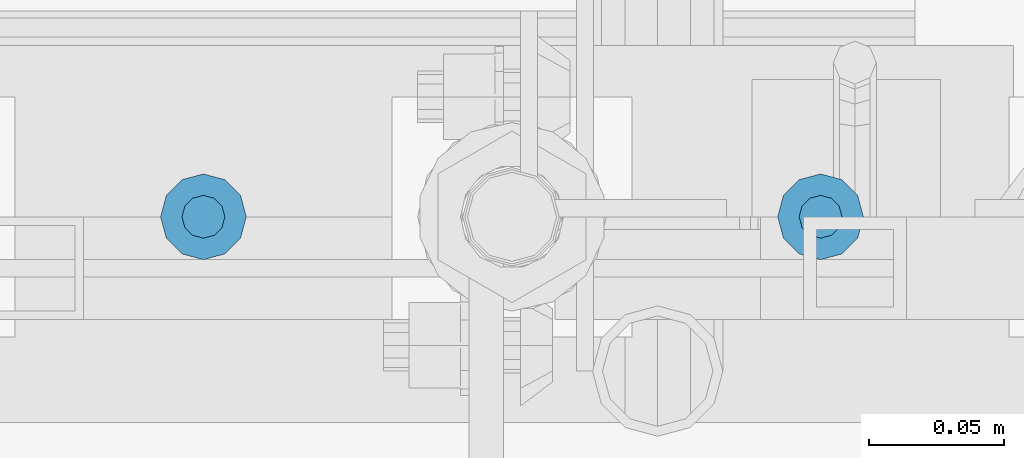
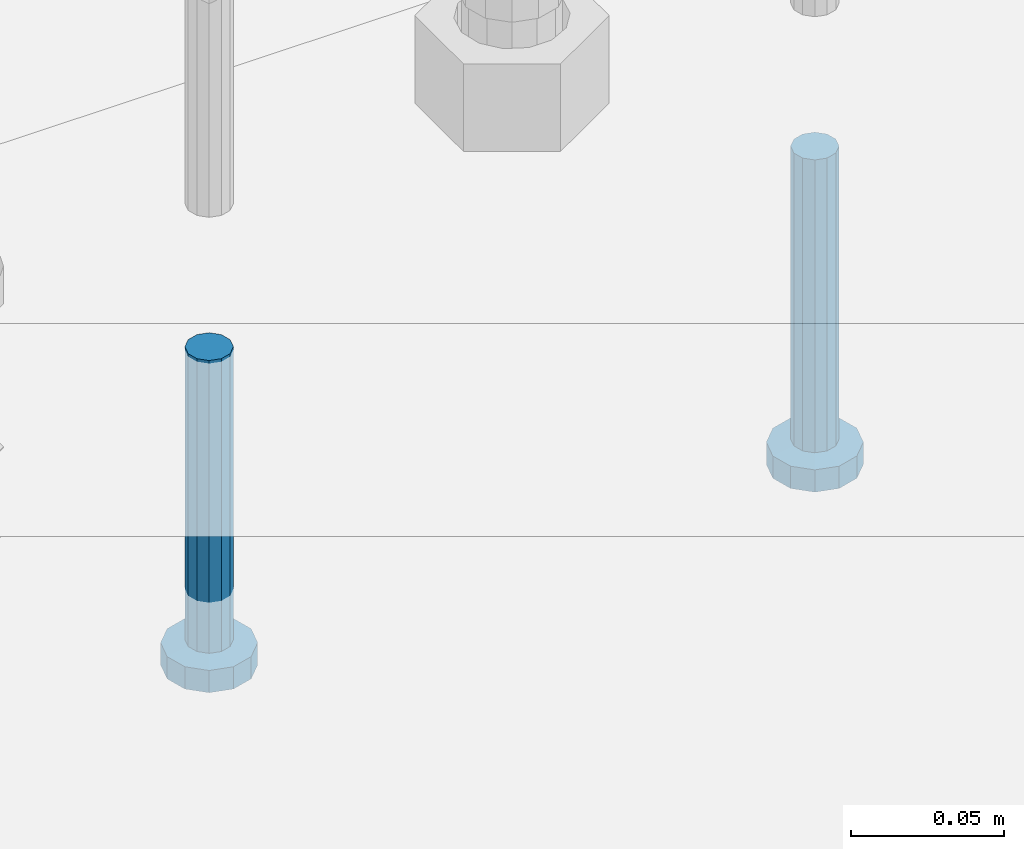
# One storey, part 1139 of 1876: 2 beams, 1 element without a shape of its own.
"""IFC2X3 building model written with IfcOpenShell, lengths in millimetres."""

from ifc_helpers import new_model, si_unit, frame, origin_with_axes, place, context, subcontext, project, spatial, faceted_brep, material, type_object, element, aggregate, save


model = new_model("IFC2X3")

# Units and contexts
model_context = context("Model", 3, precision=1e-05, world=origin_with_axes())
body_context = subcontext(model_context, "Body", "Model", "MODEL_VIEW")
ifc_project = project(units=[si_unit("LENGTHUNIT", "METRE", prefix="MILLI"), si_unit("AREAUNIT", "SQUARE_METRE"), si_unit("VOLUMEUNIT", "CUBIC_METRE"), si_unit("MASSUNIT", "GRAM", prefix="KILO"), si_unit("TIMEUNIT", "SECOND"), si_unit("PLANEANGLEUNIT", "RADIAN"), si_unit("SOLIDANGLEUNIT", "STERADIAN"), si_unit("THERMODYNAMICTEMPERATUREUNIT", "DEGREE_CELSIUS"), si_unit("LUMINOUSINTENSITYUNIT", "LUMEN")], contexts=[model_context])

# Site, building, storey
site_placement = place(None, origin_with_axes())
site = spatial("IfcSite", under=ifc_project, at=site_placement, CompositionType="ELEMENT")
building_placement = place(site_placement, origin_with_axes())
building = spatial("IfcBuilding", under=site, at=building_placement, Name="Undefined", CompositionType="ELEMENT")
storey_placement = place(building_placement, origin_with_axes())
storey = spatial("IfcBuildingStorey", under=building, at=storey_placement, Name="Undefined", CompositionType="ELEMENT", Elevation=0.0)

# Assembly, beams
assembly_placement = place(storey_placement, origin_with_axes())
assembly = element("IfcElementAssembly", 1, at=assembly_placement, inside=storey, Name="TEMPLATE", AssemblyPlace="NOTDEFINED", PredefinedType="RIGID_FRAME")
ifc_material = material(Name="STEEL/A108")
beam_type = type_object("IfcBeamType", Name="5/8-DIA_HEADED ANCHOR STUD", PredefinedType="NOTDEFINED")
beam_1_placement = place(assembly_placement, frame((1841.5, -6883.4, -819.15), z_axis=(1.0, 0.0, 0.0), x_axis=(0.0, 0.0, -1.0)))
beam_1 = element("IfcBeam", 2, at=beam_1_placement, type_object=beam_type, material=ifc_material, Name="HEADED ANCHOR STUD", ObjectType="5/8-DIA_HEADED ANCHOR STUD", context=body_context, shape_type="Brep", body=[
    faceted_brep([(0.0, -7.94000005722046, 0.0), (0.0, -6.86999988555908, -3.97000002861023), (116.84, -6.86999988555908, -3.97000002861023), (116.84, -7.94000005722046, 0.0), (0.0, -3.97000002861023, -6.86999988555908), (116.84, -3.97000002861023, -6.86999988555908), (0.0, 0.0, -7.94000005722046), (116.84, 0.0, -7.94000005722046), (0.0, 3.97000002861023, -6.86999988555908), (116.84, 3.97000002861023, -6.86999988555908), (0.0, 6.86999988555908, -3.97000002861023), (116.84, 6.86999988555908, -3.97000002861023), (0.0, 7.94000005722046, 0.0), (116.84, 7.94000005722046, 0.0), (0.0, 6.86999988555908, 3.97000002861023), (116.84, 6.86999988555908, 3.97000002861023), (0.0, 3.97000002861023, 6.86999988555908), (116.84, 3.97000002861023, 6.86999988555908), (0.0, 0.0, 7.94000005722046), (116.84, 0.0, 7.94000005722046), (0.0, -3.97000002861023, 6.86999988555908), (116.84, -3.97000002861023, 6.86999988555908), (0.0, -6.86999988555908, 3.97000002861023), (116.84, -6.86999988555908, 3.97000002861023), (118.11, -13.75, -7.94000005722046), (118.11, -15.8800001144409, 0.0), (118.11, -7.94000005722046, -13.75), (118.11, 0.0, -15.8800001144409), (118.11, 7.94000005722046, -13.75), (118.11, 13.75, -7.94000005722046), (118.11, 15.8800001144409, 0.0), (118.11, 13.75, 7.94000005722046), (118.11, 7.94000005722046, 13.75), (118.11, 0.0, 15.8800001144409), (118.11, -7.94000005722046, 13.75), (118.11, -13.75, 7.94000005722046), (127.0, -13.75, -7.94000005722046), (127.0, -15.8800001144409, 0.0), (127.0, -7.94000005722046, -13.75), (127.0, 0.0, -15.8800001144409), (127.0, 7.94000005722046, -13.75), (127.0, 13.75, -7.94000005722046), (127.0, 15.8800001144409, 0.0), (127.0, 13.75, 7.94000005722046), (127.0, 7.94000005722046, 13.75), (127.0, 0.0, 15.8800001144409), (127.0, -7.94000005722046, 13.75), (127.0, -13.75, 7.94000005722046)], [[[0, 1, 2, 3]], [[1, 4, 5, 2]], [[4, 6, 7, 5]], [[6, 8, 9, 7]], [[8, 10, 11, 9]], [[10, 12, 13, 11]], [[12, 14, 15, 13]], [[14, 16, 17, 15]], [[16, 18, 19, 17]], [[18, 20, 21, 19]], [[20, 22, 23, 21]], [[22, 0, 3, 23]], [[22, 20, 18, 16, 14, 12, 10, 8, 6, 4, 1, 0]], [[3, 2, 24, 25]], [[2, 5, 26, 24]], [[5, 7, 27, 26]], [[7, 9, 28, 27]], [[9, 11, 29, 28]], [[11, 13, 30, 29]], [[13, 15, 31, 30]], [[15, 17, 32, 31]], [[17, 19, 33, 32]], [[19, 21, 34, 33]], [[21, 23, 35, 34]], [[23, 3, 25, 35]], [[25, 24, 36, 37]], [[24, 26, 38, 36]], [[26, 27, 39, 38]], [[27, 28, 40, 39]], [[28, 29, 41, 40]], [[29, 30, 42, 41]], [[30, 31, 43, 42]], [[31, 32, 44, 43]], [[32, 33, 45, 44]], [[33, 34, 46, 45]], [[34, 35, 47, 46]], [[35, 25, 37, 47]], [[38, 39, 40, 41, 42, 43, 44, 45, 46, 47, 37, 36]]]),
])
beam_2_placement = place(assembly_placement, frame((1612.9, -6883.4, -819.15), z_axis=(1.0, 0.0, 0.0), x_axis=(0.0, 0.0, -1.0)))
beam_2 = element("IfcBeam", 3, at=beam_2_placement, type_object=beam_type, material=ifc_material, Name="HEADED ANCHOR STUD", ObjectType="5/8-DIA_HEADED ANCHOR STUD", context=body_context, shape_type="Brep", body=[
    faceted_brep([(0.0, -7.94000005722046, 0.0), (0.0, -6.86999988555908, -3.97000002861023), (116.84, -6.86999988555908, -3.97000002861023), (116.84, -7.94000005722046, 0.0), (0.0, -3.97000002861023, -6.86999988555908), (116.84, -3.97000002861023, -6.86999988555908), (0.0, 0.0, -7.94000005722046), (116.84, 0.0, -7.94000005722046), (0.0, 3.97000002861023, -6.86999988555908), (116.84, 3.97000002861023, -6.86999988555908), (0.0, 6.86999988555908, -3.97000002861023), (116.84, 6.86999988555908, -3.97000002861023), (0.0, 7.94000005722046, 0.0), (116.84, 7.94000005722046, 0.0), (0.0, 6.86999988555908, 3.97000002861023), (116.84, 6.86999988555908, 3.97000002861023), (0.0, 3.97000002861023, 6.86999988555908), (116.84, 3.97000002861023, 6.86999988555908), (0.0, 0.0, 7.94000005722046), (116.84, 0.0, 7.94000005722046), (0.0, -3.97000002861023, 6.86999988555908), (116.84, -3.97000002861023, 6.86999988555908), (0.0, -6.86999988555908, 3.97000002861023), (116.84, -6.86999988555908, 3.97000002861023), (118.11, -13.75, -7.94000005722046), (118.11, -15.8800001144409, 0.0), (118.11, -7.94000005722046, -13.75), (118.11, 0.0, -15.8800001144409), (118.11, 7.94000005722046, -13.75), (118.11, 13.75, -7.94000005722046), (118.11, 15.8800001144409, 0.0), (118.11, 13.75, 7.94000005722046), (118.11, 7.94000005722046, 13.75), (118.11, 0.0, 15.8800001144409), (118.11, -7.94000005722046, 13.75), (118.11, -13.75, 7.94000005722046), (127.0, -13.75, -7.94000005722046), (127.0, -15.8800001144409, 0.0), (127.0, -7.94000005722046, -13.75), (127.0, 0.0, -15.8800001144409), (127.0, 7.94000005722046, -13.75), (127.0, 13.75, -7.94000005722046), (127.0, 15.8800001144409, 0.0), (127.0, 13.75, 7.94000005722046), (127.0, 7.94000005722046, 13.75), (127.0, 0.0, 15.8800001144409), (127.0, -7.94000005722046, 13.75), (127.0, -13.75, 7.94000005722046)], [[[0, 1, 2, 3]], [[1, 4, 5, 2]], [[4, 6, 7, 5]], [[6, 8, 9, 7]], [[8, 10, 11, 9]], [[10, 12, 13, 11]], [[12, 14, 15, 13]], [[14, 16, 17, 15]], [[16, 18, 19, 17]], [[18, 20, 21, 19]], [[20, 22, 23, 21]], [[22, 0, 3, 23]], [[22, 20, 18, 16, 14, 12, 10, 8, 6, 4, 1, 0]], [[3, 2, 24, 25]], [[2, 5, 26, 24]], [[5, 7, 27, 26]], [[7, 9, 28, 27]], [[9, 11, 29, 28]], [[11, 13, 30, 29]], [[13, 15, 31, 30]], [[15, 17, 32, 31]], [[17, 19, 33, 32]], [[19, 21, 34, 33]], [[21, 23, 35, 34]], [[23, 3, 25, 35]], [[25, 24, 36, 37]], [[24, 26, 38, 36]], [[26, 27, 39, 38]], [[27, 28, 40, 39]], [[28, 29, 41, 40]], [[29, 30, 42, 41]], [[30, 31, 43, 42]], [[31, 32, 44, 43]], [[32, 33, 45, 44]], [[33, 34, 46, 45]], [[34, 35, 47, 46]], [[35, 25, 37, 47]], [[38, 39, 40, 41, 42, 43, 44, 45, 46, 47, 37, 36]]]),
])
aggregate(assembly, [beam_1, beam_2])

save(model, "model.ifc")
